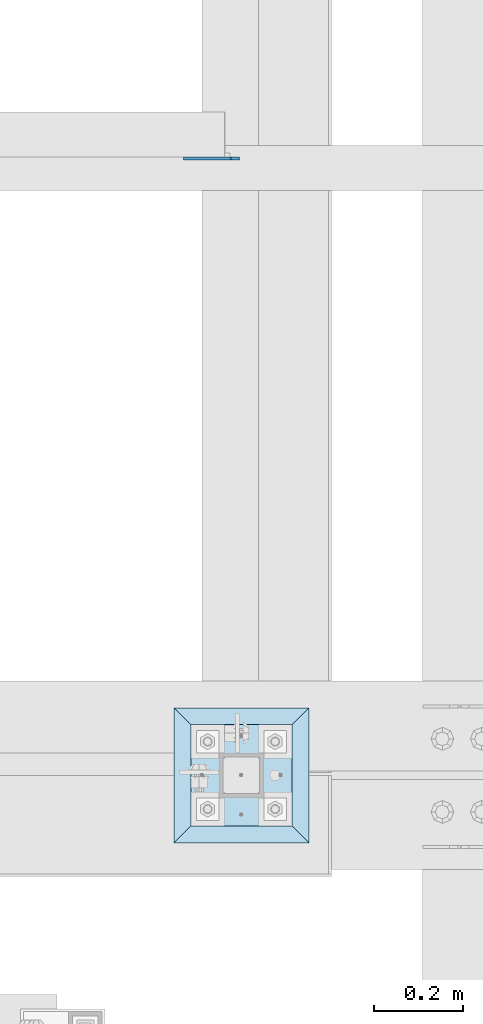
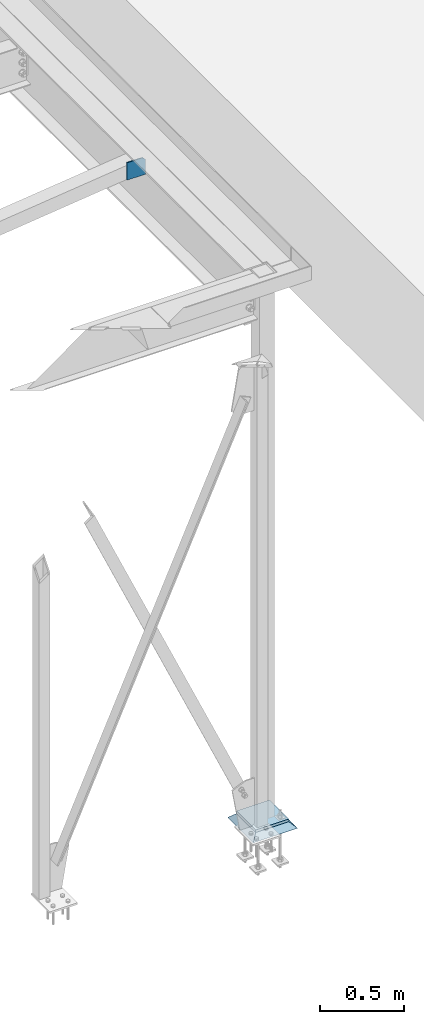
# One storey, part 3220 of 3843: 3 plates, 3 elements without a shape of their own.
"""IFC2X3 building model written with IfcOpenShell, lengths in millimetres."""

import ifcopenshell
import ifcopenshell.guid

model = None  # the IFC model being written
_history = None  # IfcOwnerHistory: only IFC2X3 demands one
_inside = {}  # id of a spatial element -> (the spatial element, [elements in it])
_under = {}  # id of a project, library or spatial element -> (it, [spatial elements below it])
_declared = {}  # id of a project -> (the project, [libraries it declares])
_typed = {}  # id of a type object -> (the type object, [elements of that type])
_made_of = {}  # id of a material, layer set ... -> (it, [elements and type objects made of it])


def new_model(schema):
    """Start an empty IFC model of exactly this schema.

    Asked for "IFC4X3", IfcOpenShell would pick the latest addendum, in which some entities
    have other attributes; the version numbers below select the first issue.
    IFC2X3 requires an IfcOwnerHistory on every rooted entity: one is made here for all.
    """
    global model, _history
    if schema == "IFC4X3":
        model = ifcopenshell.file(schema_version=(4, 3, 0, 0))
    else:
        model = ifcopenshell.file(schema=schema)
    _inside.clear()
    _under.clear()
    _declared.clear()
    _typed.clear()
    _made_of.clear()
    _history = None
    if model.schema == "IFC2X3":
        org = make("IfcOrganization", Name="unknown")
        user = make(
            "IfcPersonAndOrganization",
            ThePerson=make("IfcPerson", FamilyName="unknown"),
            TheOrganization=org,
        )
        app = make(
            "IfcApplication",
            ApplicationDeveloper=org,
            Version="unknown",
            ApplicationFullName="unknown",
            ApplicationIdentifier="unknown",
        )
        _history = make(
            "IfcOwnerHistory",
            OwningUser=user,
            OwningApplication=app,
            ChangeAction="ADDED",
            CreationDate=0,
        )
    return model


def make(cls, **values):
    """One entity of the class cls with the attributes given. An attribute that is None is left unset."""
    return model.create_entity(
        cls, **{name: value for name, value in values.items() if value is not None}
    )


def rooted(cls, **values):
    """An entity with a GlobalId (a new one), such as an element, a storey or a relation."""
    return make(cls, GlobalId=ifcopenshell.guid.new(), OwnerHistory=_history, **values)


def si_unit(unit_type, name, prefix=None):
    """IfcSIUnit, for example si_unit("LENGTHUNIT", "METRE", prefix="MILLI")."""
    return make("IfcSIUnit", UnitType=unit_type, Prefix=prefix, Name=name)


def assignment(units):
    """IfcUnitAssignment: the units of a project."""
    return None if units is None else make("IfcUnitAssignment", Units=units)


def point(xyz):
    """IfcCartesianPoint."""
    return None if xyz is None else make("IfcCartesianPoint", Coordinates=xyz)


def direction(xyz):
    """IfcDirection."""
    return None if xyz is None else make("IfcDirection", DirectionRatios=xyz)


def frame(location, z_axis=None, x_axis=None):
    """IfcAxis2Placement3D, a coordinate frame: its origin and axes. An axis left out is left unset."""
    return make(
        "IfcAxis2Placement3D",
        Location=point(location),
        Axis=direction(z_axis),
        RefDirection=direction(x_axis),
    )


def origin_with_axes():
    """The frame at (0, 0, 0) with the z axis (0, 0, 1) and the x axis (1, 0, 0) written out."""
    return frame((0.0, 0.0, 0.0), z_axis=(0.0, 0.0, 1.0), x_axis=(1.0, 0.0, 0.0))


def place(relative_to, where):
    """IfcLocalPlacement: puts the frame where relative to a parent placement (None: the world)."""
    return make(
        "IfcLocalPlacement", PlacementRelTo=relative_to, RelativePlacement=where
    )


def context(
    kind, dimensions, precision=None, world=None, true_north=None, identifier=None
):
    """IfcGeometricRepresentationContext, for example the 3D "Model" context."""
    return make(
        "IfcGeometricRepresentationContext",
        ContextIdentifier=identifier,
        ContextType=kind,
        CoordinateSpaceDimension=dimensions,
        Precision=precision,
        WorldCoordinateSystem=world,
        TrueNorth=true_north,
    )


def subcontext(parent, identifier, kind, view, scale=None):
    """IfcGeometricRepresentationSubContext, for example "Body" below "Model"."""
    return make(
        "IfcGeometricRepresentationSubContext",
        ContextIdentifier=identifier,
        ContextType=kind,
        ParentContext=parent,
        TargetScale=scale,
        TargetView=view,
    )


def project(units=None, contexts=None):
    """IfcProject with its units and contexts."""
    return rooted(
        "IfcProject",
        Name="project",
        RepresentationContexts=contexts,
        UnitsInContext=assignment(units),
    )


def spatial(cls, under=None, at=None, **own):
    """A site, building, storey or space (cls), placed at a placement, below another one or the project."""
    s = rooted(cls, ObjectPlacement=at, **own)
    if under is not None:
        _under.setdefault(under.id(), (under, []))[1].append(s)
    return s


def faces_of(points, faces, orient=None, outer=None):
    """IfcFace entities. A face is a list of loops; a loop is a list of indices into points, from 0.

    orient and outer hold one flag for each loop. By default every Orientation is true, the
    first loop of a face is its IfcFaceOuterBound and the others are IfcFaceBound.
    """
    made = []
    for i, loops in enumerate(faces):
        bounds = []
        for j, loop in enumerate(loops):
            is_outer = j == 0 if outer is None else outer[i][j]
            bounds.append(
                make(
                    "IfcFaceOuterBound" if is_outer else "IfcFaceBound",
                    Bound=make("IfcPolyLoop", Polygon=[points[k] for k in loop]),
                    Orientation=True if orient is None else orient[i][j],
                )
            )
        made.append(make("IfcFace", Bounds=bounds))
    return made


def faceted_brep(points, faces, orient=None, outer=None, voids=None):
    """IfcFacetedBrep: a solid bounded by flat faces; with voids (closed shells), ...WithVoids."""
    shared = [point(p) for p in points]
    hull = make("IfcClosedShell", CfsFaces=faces_of(shared, faces, orient, outer))
    if voids is None:
        return make("IfcFacetedBrep", Outer=hull)
    return make(
        "IfcFacetedBrepWithVoids",
        Outer=hull,
        Voids=[
            make(cls, CfsFaces=faces_of(shared, fs, o, b)) for cls, fs, o, b in voids
        ],
    )


def shape(context_of_items, identifier, shape_type, items):
    """IfcShapeRepresentation: the items that make up one representation, for example the "Body"."""
    return make(
        "IfcShapeRepresentation",
        ContextOfItems=context_of_items,
        RepresentationIdentifier=identifier,
        RepresentationType=shape_type,
        Items=items,
    )


def material(Name=None, Category=None):
    """IfcMaterial."""
    return make("IfcMaterial", Name=Name, Category=Category)


def made_of(thing, what):
    """Note that an element or type object is made of a material, layer set ...; save() writes the relation."""
    if what is not None:
        _made_of.setdefault(what.id(), (what, []))[1].append(thing)
    return thing


def type_object(cls, material=None, **own):
    """A type object (cls), such as IfcWallType, which elements share."""
    return made_of(rooted(cls, **own), material)


def element(
    cls,
    number,
    at=None,
    inside=None,
    cuts=None,
    type_object=None,
    material=None,
    context=None,
    identifier="Body",
    shape_type=None,
    held_by="IfcProductDefinitionShape",
    body=None,
    shapes=None,
    **own,
):
    """One element of the class cls, such as IfcWall. Its Tag is "e" and its number.

    at: its placement. inside: the storey or other place that contains it. cuts: it is an
    opening in that element (IfcRelVoidsElement). A single representation is given by context,
    identifier, shape_type and body (its items); several are given by shapes. held_by: the class
    of the entity that holds the representations. save() writes the other relations.
    """
    e = rooted(cls, Tag="e%d" % number, ObjectPlacement=at, **own)
    if body is not None:
        shapes = [shape(context, identifier, shape_type, body)]
    if shapes is not None:
        e.Representation = make(held_by, Representations=shapes)
    if inside is not None:
        _inside.setdefault(inside.id(), (inside, []))[1].append(e)
    if cuts is not None:
        rooted(
            "IfcRelVoidsElement", RelatingBuildingElement=cuts, RelatedOpeningElement=e
        )
    if type_object is not None:
        _typed.setdefault(type_object.id(), (type_object, []))[1].append(e)
    return made_of(e, material)


def aggregate(whole, parts):
    """IfcRelAggregates: a whole, such as a stair, and the parts it consists of."""
    return rooted("IfcRelAggregates", RelatingObject=whole, RelatedObjects=parts)


def save(model, path):
    """Write the relations noted so far, then the file.

    IfcRelAggregates (storeys below a building ...), IfcRelContainedInSpatialStructure (elements
    in a storey), IfcRelDefinesByType, IfcRelAssociatesMaterial and IfcRelDeclares: one each for
    every whole, place, type object, material and project.
    """
    for whole, parts in _under.values():
        aggregate(whole, parts)
    for where, things in _inside.values():
        rooted(
            "IfcRelContainedInSpatialStructure",
            RelatedElements=things,
            RelatingStructure=where,
        )
    for kind, things in _typed.values():
        rooted("IfcRelDefinesByType", RelatedObjects=things, RelatingType=kind)
    for what, things in _made_of.values():
        rooted("IfcRelAssociatesMaterial", RelatedObjects=things, RelatingMaterial=what)
    for by, libraries in _declared.values():
        rooted("IfcRelDeclares", RelatingContext=by, RelatedDefinitions=libraries)
    model.write(path)


model = new_model("IFC2X3")

# Units and contexts
model_context = context("Model", 3, precision=1e-05, world=origin_with_axes())
body_context = subcontext(model_context, "Body", "Model", "MODEL_VIEW")
ifc_project = project(units=[si_unit("LENGTHUNIT", "METRE", prefix="MILLI"), si_unit("AREAUNIT", "SQUARE_METRE"), si_unit("VOLUMEUNIT", "CUBIC_METRE"), si_unit("MASSUNIT", "GRAM", prefix="KILO"), si_unit("TIMEUNIT", "SECOND"), si_unit("PLANEANGLEUNIT", "RADIAN"), si_unit("SOLIDANGLEUNIT", "STERADIAN"), si_unit("THERMODYNAMICTEMPERATUREUNIT", "DEGREE_CELSIUS"), si_unit("LUMINOUSINTENSITYUNIT", "LUMEN")], contexts=[model_context])

# Site, building, storey
site_placement = place(None, origin_with_axes())
site = spatial("IfcSite", under=ifc_project, at=site_placement, CompositionType="ELEMENT")
building_placement = place(site_placement, origin_with_axes())
building = spatial("IfcBuilding", under=site, at=building_placement, Name="Undefined", CompositionType="ELEMENT")
storey_placement = place(building_placement, origin_with_axes())
storey = spatial("IfcBuildingStorey", under=building, at=storey_placement, Name="Undefined", CompositionType="ELEMENT", Elevation=0.0)

# Assembly, plate
assembly_1_placement = place(storey_placement, origin_with_axes())
assembly_1 = element("IfcElementAssembly", 1, at=assembly_1_placement, inside=storey, Name="BEAM", AssemblyPlace="NOTDEFINED", PredefinedType="RIGID_FRAME")
ifc_material_1 = material(Name="STEEL/A572-50")
plate_type_1 = type_object("IfcPlateType", PredefinedType="NOTDEFINED")
plate_1_placement = place(assembly_1_placement, frame((38816.75625, 35238.332812, 33896.3), z_axis=(0.0, 0.0, 1.0), x_axis=(-1.0, 0.0, 0.0)))
plate_1 = element("IfcPlate", 2, at=plate_1_placement, type_object=plate_type_1, material=ifc_material_1, Name="PLATE", context=body_context, shape_type="Brep", body=[
    faceted_brep([(0.0, -3.17499999999927, 0.0), (0.0, -3.17500000000291, 107.950000000004), (0.0, 3.17500000000291, 107.950000000004), (0.0, 3.17499999999927, 0.0), (19.0500000000029, -3.17500000000291, 127.0), (19.0500000000029, 3.17500000000291, 127.0), (127.0, -3.17500000000291, 127.0), (127.0, 3.17500000000291, 127.0), (127.0, -3.17500000000291, 0.0), (127.0, 3.17500000000291, 0.0)], [[[0, 1, 2, 3]], [[1, 4, 5, 2]], [[4, 6, 7, 5]], [[6, 8, 9, 7]], [[8, 0, 3, 9]], [[5, 7, 9, 3, 2]], [[8, 6, 4, 1, 0]]]),
])
aggregate(assembly_1, [plate_1])

assembly_2_placement = place(storey_placement, origin_with_axes())
assembly_2 = element("IfcElementAssembly", 3, at=assembly_2_placement, inside=storey, Name="COLUMN", AssemblyPlace="NOTDEFINED", PredefinedType="RIGID_FRAME")
plate_type_2 = type_object("IfcPlateType", PredefinedType="NOTDEFINED")
plate_2_placement = place(assembly_2_placement, frame((38706.425, 33731.2, 30070.425), z_axis=(0.0, 1.0, 0.0), x_axis=(1.0, 0.0, 0.0)))
plate_2 = element("IfcPlate", 4, at=plate_2_placement, type_object=plate_type_2, material=ifc_material_1, Name="PLATE", context=body_context, shape_type="Brep", body=[
    faceted_brep([(0.0, -9.52500000000146, 0.0), (0.0, -9.52500000000146, 228.600006103516), (0.0, 9.52500000000146, 228.600006103516), (0.0, 9.52500000000146, 0.0), (228.600006103516, -9.52500000000146, 228.600006103516), (228.600006103516, 9.52500000000146, 228.600006103516), (228.599999999999, -9.52500000000146, 0.0), (228.599999999999, 9.52500000000146, 0.0)], [[[0, 1, 2, 3]], [[1, 4, 5, 2]], [[4, 6, 7, 5]], [[6, 0, 3, 7]], [[5, 7, 3, 2]], [[6, 4, 1, 0]]]),
])
aggregate(assembly_2, [plate_2])

assembly_3_placement = place(storey_placement, origin_with_axes())
assembly_3 = element("IfcElementAssembly", 5, at=assembly_3_placement, inside=storey, Name="GROUT", AssemblyPlace="NOTDEFINED", PredefinedType="REINFORCEMENT_UNIT")
ifc_material_2 = material(Name="CONCRETE/Concrete_Undefined")
plate_type_3 = type_object("IfcPlateType", PredefinedType="NOTDEFINED")
plate_3_placement = place(assembly_3_placement, frame((38668.325, 33693.1, 30041.85), z_axis=(0.0, 1.0, 0.0), x_axis=(1.0, 0.0, 0.0)))
plate_3 = element("IfcPlate", 6, at=plate_3_placement, type_object=plate_type_3, material=ifc_material_2, Name="GROUT", context=body_context, shape_type="Brep", body=[
    faceted_brep([(38.0999999997875, -19.0499999997883, 266.699999999328), (0.0, 19.0499999999993, 304.799987792969), (0.0, 19.0500000000029, 0.0), (38.1000000006916, -19.0499999999811, 38.1000000006607), (266.700000000201, -19.0499999998174, 38.1000000006752), (304.799987792969, 19.0499999999993, 0.0), (304.799987792969, 19.0499999999993, 304.799987792969), (266.700000000201, -19.0499999999738, 266.699999999328)], [[[0, 1, 2, 3]], [[4, 5, 6, 7]], [[4, 7, 0, 3]], [[5, 4, 3, 2]], [[6, 5, 2, 1]], [[7, 6, 1, 0]]]),
])
aggregate(assembly_3, [plate_3])

save(model, "model.ifc")
